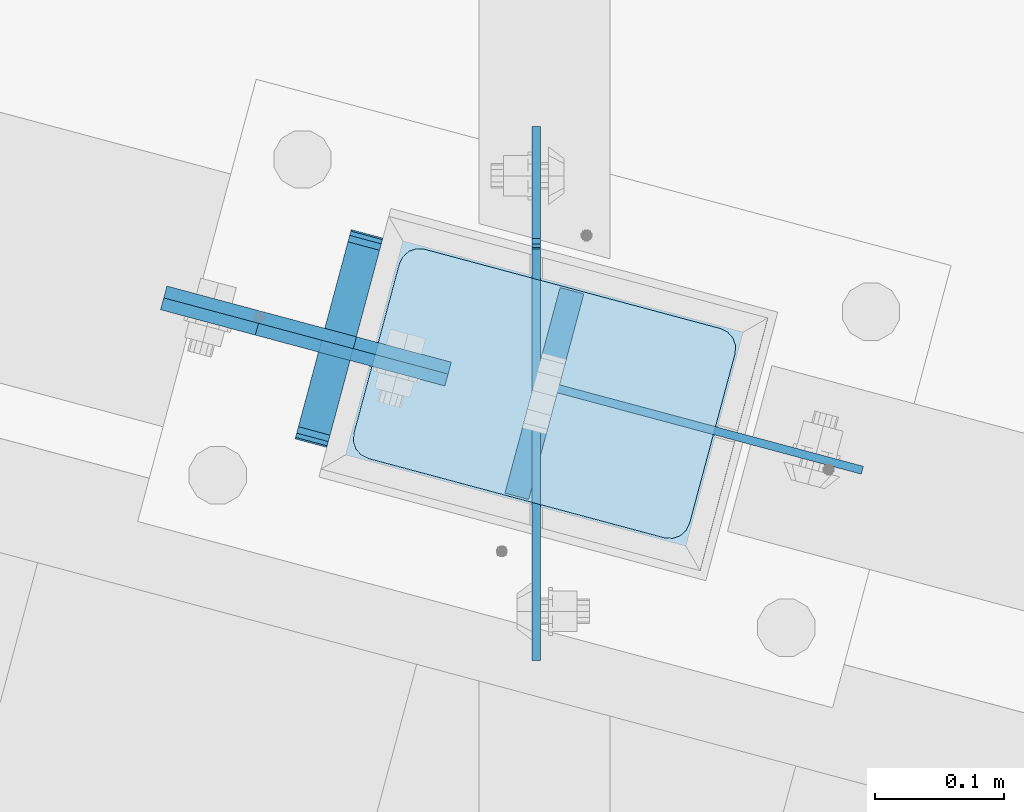
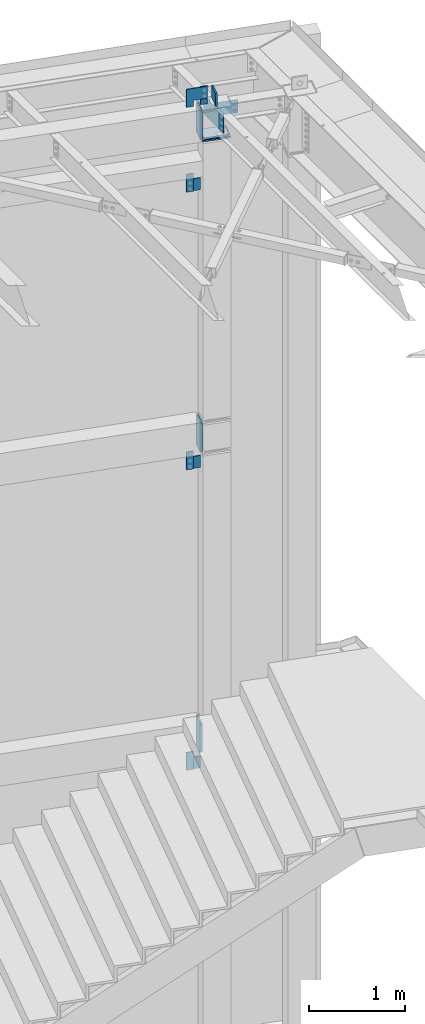
# One storey, part 1702 of 1763: 17 plates, 5 elements without a shape of their own.
"""IFC2X3 building model written with IfcOpenShell, lengths in millimetres."""

from ifc_helpers import new_model, si_unit, frame, origin_with_axes, place, context, subcontext, project, spatial, faceted_brep, material, type_object, element, aggregate, save


model = new_model("IFC2X3")

# Units and contexts
model_context = context("Model", 3, precision=1e-05, world=origin_with_axes())
body_context = subcontext(model_context, "Body", "Model", "MODEL_VIEW")
ifc_project = project(units=[si_unit("LENGTHUNIT", "METRE", prefix="MILLI"), si_unit("AREAUNIT", "SQUARE_METRE"), si_unit("VOLUMEUNIT", "CUBIC_METRE"), si_unit("MASSUNIT", "GRAM", prefix="KILO"), si_unit("TIMEUNIT", "SECOND"), si_unit("PLANEANGLEUNIT", "RADIAN"), si_unit("SOLIDANGLEUNIT", "STERADIAN"), si_unit("THERMODYNAMICTEMPERATUREUNIT", "DEGREE_CELSIUS"), si_unit("LUMINOUSINTENSITYUNIT", "LUMEN")], contexts=[model_context])

# Site, building, storey
site_placement = place(None, origin_with_axes())
site = spatial("IfcSite", under=ifc_project, at=site_placement, CompositionType="ELEMENT")
building_placement = place(site_placement, origin_with_axes())
building = spatial("IfcBuilding", under=site, at=building_placement, Name="Undefined", CompositionType="ELEMENT")
storey_placement = place(building_placement, origin_with_axes())
storey = spatial("IfcBuildingStorey", under=building, at=storey_placement, Name="Undefined", CompositionType="ELEMENT", Elevation=0.0)

# Assembly, plate
assembly_1_placement = place(storey_placement, origin_with_axes())
assembly_1 = element("IfcElementAssembly", 1, at=assembly_1_placement, inside=storey, Name="BEAM", AssemblyPlace="NOTDEFINED", PredefinedType="RIGID_FRAME")
ifc_material_1 = material(Name="STEEL/A36")
plate_type_1 = type_object("IfcPlateType", PredefinedType="NOTDEFINED")
plate_1_placement = place(assembly_1_placement, frame((-22769.6055248915, 62142.4810116845, 11598.2749999997), z_axis=(0.0, 0.0, -1.0), x_axis=(-0.965925827679309, 0.258819039914073, 0.0)))
plate_1 = element("IfcPlate", 2, at=plate_1_placement, type_object=plate_type_1, material=ifc_material_1, Name="PLATE", context=body_context, shape_type="Brep", body=[
    faceted_brep([(0.0, -4.76249999999982, 0.0), (-2.83762346953154e-10, -4.7624999996915, 228.600006103516), (-2.83762346953154e-10, 4.76250000028813, 228.600006103517), (0.0, 4.76249999999982, 0.0), (76.1999969480166, -4.76249999961874, 228.600006103516), (76.1999969480166, 4.76250000036089, 228.600006103517), (76.1999969482931, -4.76249999991705, 0.0), (76.1999969482931, 4.76250000006257, 1.81898940354586e-12)], [[[0, 1, 2, 3]], [[1, 4, 5, 2]], [[4, 6, 7, 5]], [[6, 0, 3, 7]], [[5, 7, 3, 2]], [[6, 4, 1, 0]]]),
])
aggregate(assembly_1, [plate_1])

assembly_2_placement = place(storey_placement, origin_with_axes())
assembly_2 = element("IfcElementAssembly", 3, at=assembly_2_placement, inside=storey, Name="BEAM", AssemblyPlace="NOTDEFINED", PredefinedType="RIGID_FRAME")
plate_2_placement = place(assembly_2_placement, frame((-22769.6007483552, 62142.479719744, 4267.19999999973), z_axis=(0.0, 0.0, -1.0), x_axis=(-0.965925827679309, 0.258819039914073, 0.0)))
plate_2 = element("IfcPlate", 4, at=plate_2_placement, type_object=plate_type_1, material=ifc_material_1, Name="PLATE", context=body_context, shape_type="Brep", body=[
    faceted_brep([(0.0, -4.76249999999982, 0.0), (-2.83762346953154e-10, -4.7624999996915, 228.600006103516), (-2.83762346953154e-10, 4.76250000028813, 228.600006103517), (0.0, 4.76249999999982, 0.0), (76.1999969480166, -4.76249999961874, 228.600006103516), (76.1999969480166, 4.76250000036089, 228.600006103517), (76.1999969482931, -4.76249999991705, 0.0), (76.1999969482931, 4.76250000006257, 1.81898940354586e-12)], [[[0, 1, 2, 3]], [[1, 4, 5, 2]], [[4, 6, 7, 5]], [[6, 0, 3, 7]], [[5, 7, 3, 2]], [[6, 4, 1, 0]]]),
])

assembly_3_placement = place(storey_placement, origin_with_axes())
assembly_3 = element("IfcElementAssembly", 5, at=assembly_3_placement, inside=storey, Name="COLUMN", AssemblyPlace="NOTDEFINED", PredefinedType="RIGID_FRAME")
plate_3_placement = place(assembly_3_placement, frame((-22619.9332028245, 62112.2374404424, 12446.0), z_axis=(0.0, 0.0, 1.0), x_axis=(-0.965925827679309, 0.258819039914073, 0.0)))
plate_3 = element("IfcPlate", 6, at=plate_3_placement, type_object=plate_type_1, material=ifc_material_1, Name="PLATE", context=body_context, shape_type="Brep", body=[
    faceted_brep([(0.0, -4.76249999999982, 0.0), (-2.83762346953154e-10, -4.7624999996915, 228.600006103516), (-2.83762346953154e-10, 4.76250000028813, 228.600006103517), (0.0, 4.76249999999982, 0.0), (76.1999969480166, -4.76249999961874, 228.600006103516), (76.1999969480166, 4.76250000036089, 228.600006103517), (76.1999969482931, -4.76249999991705, 0.0), (76.1999969482931, 4.76250000006257, 1.81898940354586e-12)], [[[0, 1, 2, 3]], [[1, 4, 5, 2]], [[4, 6, 7, 5]], [[6, 0, 3, 7]], [[5, 7, 3, 2]], [[6, 4, 1, 0]]]),
])

assembly_4_placement = place(storey_placement, origin_with_axes())
assembly_4 = element("IfcElementAssembly", 7, at=assembly_4_placement, inside=storey, Name="BEAM", AssemblyPlace="NOTDEFINED", PredefinedType="RIGID_FRAME")
plate_4_placement = place(assembly_4_placement, frame((-22769.6007484359, 62142.4797197657, 8077.19999999973), z_axis=(0.0, 0.0, -1.0), x_axis=(-0.965925827679309, 0.258819039914073, 0.0)))
plate_4 = element("IfcPlate", 8, at=plate_4_placement, type_object=plate_type_1, material=ifc_material_1, Name="PLATE", context=body_context, shape_type="Brep", body=[
    faceted_brep([(0.0, -4.76249999999982, 0.0), (-2.83762346953154e-10, -4.7624999996915, 228.600006103516), (-2.83762346953154e-10, 4.76250000028813, 228.600006103517), (0.0, 4.76249999999982, 0.0), (76.1999969480166, -4.76249999961874, 228.600006103516), (76.1999969480166, 4.76250000036089, 228.600006103517), (76.1999969482931, -4.76249999991705, 0.0), (76.1999969482931, 4.76250000006257, 1.81898940354586e-12)], [[[0, 1, 2, 3]], [[1, 4, 5, 2]], [[4, 6, 7, 5]], [[6, 0, 3, 7]], [[5, 7, 3, 2]], [[6, 4, 1, 0]]]),
])

assembly_5_placement = place(storey_placement, origin_with_axes())
assembly_5 = element("IfcElementAssembly", 9, at=assembly_5_placement, inside=storey, Name="BEAM", AssemblyPlace="NOTDEFINED", PredefinedType="RIGID_FRAME")
plate_type_2 = type_object("IfcPlateType", PredefinedType="NOTDEFINED")
plate_5_placement = place(assembly_5_placement, frame((-22684.0855655107, 62216.539341723, 12057.0970057414), z_axis=(-1.25579324012506e-05, -4.68677477038e-05, 0.999999998822856), x_axis=(-0.258819045024454, -0.965925825091317, -4.85210000061005e-05)))
plate_5 = element("IfcPlate", 10, at=plate_5_placement, type_object=plate_type_2, material=ifc_material_1, Name="PLATE", context=body_context, shape_type="Brep", body=[
    faceted_brep([(-0.000210669619264081, -12.6999999999534, 15.8747893276304), (-0.0047190601399052, -12.6999999998734, 355.599795431186), (-0.00471906022721669, 12.7000000000335, 355.599795431181), (-0.000210669699299615, 12.6999999999462, 15.874789327625), (1.2036328949398, -12.6999999998734, 361.674959615151), (1.20363289484521, 12.7000000000189, 361.674959615146), (4.64488630341657, -12.6999999998734, 366.825251770753), (4.64488630330743, 12.7000000000189, 366.825251770748), (9.79513279069943, -12.6999999998807, 370.266573526937), (9.79513279059029, 12.7000000000116, 370.266573526933), (15.870280938434, -12.6999999998952, 371.47500610361), (15.8702809383467, 12.7000000000044, 371.475006103608), (152.395291187866, -12.7000000001281, 371.475006103574), (152.395291187757, 12.6999999997643, 371.475006103572), (158.470342028959, -12.7000000001353, 370.266613832635), (158.47034202885, 12.699999999757, 370.266613832629), (163.620536872309, -12.7000000001644, 366.825400721296), (163.620536872222, 12.6999999997352, 366.825400721291), (167.061818314192, -12.7000000001644, 361.675251535087), (167.06181831409, 12.6999999997279, 361.675251535082), (168.270291186484, -12.7000000001644, 355.600216727018), (168.270291186389, 12.6999999997279, 355.600216727014), (168.274798528968, -12.7000000002445, 15.8752106238717), (168.274798528873, 12.6999999996478, 15.8752106238662), (167.066446559853, -12.7000000002445, 9.80004645495683), (167.066446559766, 12.6999999996551, 9.80004645495319), (163.625193148131, -12.7000000002372, 4.64975431598214), (163.625193148022, 12.6999999996478, 4.64975431597668), (158.474946666858, -12.7000000002372, 1.2084325724245), (158.474946666771, 12.6999999996624, 1.20843257241904), (152.399798530452, -12.7000000002226, 4.20186552219093e-10), (152.399798530358, 12.6999999996697, 4.14729584008455e-10), (15.8747893290638, -12.6999999999898, 4.72937244921923e-11), (15.8747893289692, 12.6999999999098, 4.36557456851006e-11), (9.79973849928501, -12.699999999968, 1.20839226628777), (9.79973849918315, 12.6999999999243, 1.20839226628414), (4.64954366190068, -12.699999999968, 4.6496053649953), (4.64954366179882, 12.6999999999316, 4.64960536499166), (1.20826221675816, -12.6999999999607, 9.79975453459156), (1.20826221665629, 12.6999999999462, 9.79975453458792)], [[[0, 1, 2, 3]], [[1, 4, 5, 2]], [[4, 6, 7, 5]], [[6, 8, 9, 7]], [[8, 10, 11, 9]], [[10, 12, 13, 11]], [[12, 14, 15, 13]], [[14, 16, 17, 15]], [[16, 18, 19, 17]], [[18, 20, 21, 19]], [[20, 22, 23, 21]], [[22, 24, 25, 23]], [[24, 26, 27, 25]], [[26, 28, 29, 27]], [[28, 30, 31, 29]], [[30, 32, 33, 31]], [[32, 34, 35, 33]], [[34, 36, 37, 35]], [[36, 38, 39, 37]], [[38, 0, 3, 39]], [[5, 7, 9, 11, 13, 15, 17, 19, 21, 23, 25, 27, 29, 31, 33, 35, 37, 39, 3, 2]], [[38, 36, 34, 32, 30, 28, 26, 24, 22, 20, 18, 16, 14, 12, 10, 8, 6, 4, 1, 0]]]),
])

# Plate
plate_6_placement = place(assembly_2_placement, frame((-22684.0593140873, 62216.532307673, 4284.69625868207), z_axis=(-1.25579324012506e-05, -4.68677477038e-05, 0.999999998822856), x_axis=(-0.258819045024454, -0.965925825091317, -4.85210000061005e-05)))
plate_6 = element("IfcPlate", 11, at=plate_6_placement, type_object=plate_type_2, material=ifc_material_1, Name="PLATE", context=body_context, shape_type="Brep", body=[
    faceted_brep([(-0.000210669619264081, -12.6999999999534, 15.8747893276304), (-0.0047190601399052, -12.6999999998734, 355.599795431186), (-0.00471906022721669, 12.7000000000335, 355.599795431181), (-0.000210669699299615, 12.6999999999462, 15.874789327625), (1.2036328949398, -12.6999999998734, 361.674959615151), (1.20363289484521, 12.7000000000189, 361.674959615146), (4.64488630341657, -12.6999999998734, 366.825251770753), (4.64488630330743, 12.7000000000189, 366.825251770748), (9.79513279069943, -12.6999999998807, 370.266573526937), (9.79513279059029, 12.7000000000116, 370.266573526933), (15.870280938434, -12.6999999998952, 371.47500610361), (15.8702809383467, 12.7000000000044, 371.475006103608), (152.395291187866, -12.7000000001281, 371.475006103574), (152.395291187757, 12.6999999997643, 371.475006103572), (158.470342028959, -12.7000000001353, 370.266613832635), (158.47034202885, 12.699999999757, 370.266613832629), (163.620536872309, -12.7000000001644, 366.825400721296), (163.620536872222, 12.6999999997352, 366.825400721291), (167.061818314192, -12.7000000001644, 361.675251535087), (167.06181831409, 12.6999999997279, 361.675251535082), (168.270291186484, -12.7000000001644, 355.600216727018), (168.270291186389, 12.6999999997279, 355.600216727014), (168.274798528968, -12.7000000002445, 15.8752106238717), (168.274798528873, 12.6999999996478, 15.8752106238662), (167.066446559853, -12.7000000002445, 9.80004645495683), (167.066446559766, 12.6999999996551, 9.80004645495319), (163.625193148131, -12.7000000002372, 4.64975431598214), (163.625193148022, 12.6999999996478, 4.64975431597668), (158.474946666858, -12.7000000002372, 1.2084325724245), (158.474946666771, 12.6999999996624, 1.20843257241904), (152.399798530452, -12.7000000002226, 4.20186552219093e-10), (152.399798530358, 12.6999999996697, 4.14729584008455e-10), (15.8747893290638, -12.6999999999898, 4.72937244921923e-11), (15.8747893289692, 12.6999999999098, 4.36557456851006e-11), (9.79973849928501, -12.699999999968, 1.20839226628777), (9.79973849918315, 12.6999999999243, 1.20839226628414), (4.64954366190068, -12.699999999968, 4.6496053649953), (4.64954366179882, 12.6999999999316, 4.64960536499166), (1.20826221675816, -12.6999999999607, 9.79975453459156), (1.20826221665629, 12.6999999999462, 9.79975453458792)], [[[0, 1, 2, 3]], [[1, 4, 5, 2]], [[4, 6, 7, 5]], [[6, 8, 9, 7]], [[8, 10, 11, 9]], [[10, 12, 13, 11]], [[12, 14, 15, 13]], [[14, 16, 17, 15]], [[16, 18, 19, 17]], [[18, 20, 21, 19]], [[20, 22, 23, 21]], [[22, 24, 25, 23]], [[24, 26, 27, 25]], [[26, 28, 29, 27]], [[28, 30, 31, 29]], [[30, 32, 33, 31]], [[32, 34, 35, 33]], [[34, 36, 37, 35]], [[36, 38, 39, 37]], [[38, 0, 3, 39]], [[5, 7, 9, 11, 13, 15, 17, 19, 21, 23, 25, 27, 29, 31, 33, 35, 37, 39, 3, 2]], [[38, 36, 34, 32, 30, 28, 26, 24, 22, 20, 18, 16, 14, 12, 10, 8, 6, 4, 1, 0]]]),
])

aggregate(assembly_2, [plate_6, plate_2])

plate_7_placement = place(assembly_4_placement, frame((-22684.0593141684, 62216.5323076944, 8094.69625868207), z_axis=(-1.25579324012506e-05, -4.68677477038e-05, 0.999999998822856), x_axis=(-0.258819045024454, -0.965925825091317, -4.85210000061005e-05)))
plate_7 = element("IfcPlate", 12, at=plate_7_placement, type_object=plate_type_2, material=ifc_material_1, Name="PLATE", context=body_context, shape_type="Brep", body=[
    faceted_brep([(-0.000210669619264081, -12.6999999999534, 15.8747893276304), (-0.0047190601399052, -12.6999999998734, 355.599795431186), (-0.00471906022721669, 12.7000000000335, 355.599795431181), (-0.000210669699299615, 12.6999999999462, 15.874789327625), (1.2036328949398, -12.6999999998734, 361.674959615151), (1.20363289484521, 12.7000000000189, 361.674959615146), (4.64488630341657, -12.6999999998734, 366.825251770753), (4.64488630330743, 12.7000000000189, 366.825251770748), (9.79513279069943, -12.6999999998807, 370.266573526937), (9.79513279059029, 12.7000000000116, 370.266573526933), (15.870280938434, -12.6999999998952, 371.47500610361), (15.8702809383467, 12.7000000000044, 371.475006103608), (152.395291187866, -12.7000000001281, 371.475006103574), (152.395291187757, 12.6999999997643, 371.475006103572), (158.470342028959, -12.7000000001353, 370.266613832635), (158.47034202885, 12.699999999757, 370.266613832629), (163.620536872309, -12.7000000001644, 366.825400721296), (163.620536872222, 12.6999999997352, 366.825400721291), (167.061818314192, -12.7000000001644, 361.675251535087), (167.06181831409, 12.6999999997279, 361.675251535082), (168.270291186484, -12.7000000001644, 355.600216727018), (168.270291186389, 12.6999999997279, 355.600216727014), (168.274798528968, -12.7000000002445, 15.8752106238717), (168.274798528873, 12.6999999996478, 15.8752106238662), (167.066446559853, -12.7000000002445, 9.80004645495683), (167.066446559766, 12.6999999996551, 9.80004645495319), (163.625193148131, -12.7000000002372, 4.64975431598214), (163.625193148022, 12.6999999996478, 4.64975431597668), (158.474946666858, -12.7000000002372, 1.2084325724245), (158.474946666771, 12.6999999996624, 1.20843257241904), (152.399798530452, -12.7000000002226, 4.20186552219093e-10), (152.399798530358, 12.6999999996697, 4.14729584008455e-10), (15.8747893290638, -12.6999999999898, 4.72937244921923e-11), (15.8747893289692, 12.6999999999098, 4.36557456851006e-11), (9.79973849928501, -12.699999999968, 1.20839226628777), (9.79973849918315, 12.6999999999243, 1.20839226628414), (4.64954366190068, -12.699999999968, 4.6496053649953), (4.64954366179882, 12.6999999999316, 4.64960536499166), (1.20826221675816, -12.6999999999607, 9.79975453459156), (1.20826221665629, 12.6999999999462, 9.79975453458792)], [[[0, 1, 2, 3]], [[1, 4, 5, 2]], [[4, 6, 7, 5]], [[6, 8, 9, 7]], [[8, 10, 11, 9]], [[10, 12, 13, 11]], [[12, 14, 15, 13]], [[14, 16, 17, 15]], [[16, 18, 19, 17]], [[18, 20, 21, 19]], [[20, 22, 23, 21]], [[22, 24, 25, 23]], [[24, 26, 27, 25]], [[26, 28, 29, 27]], [[28, 30, 31, 29]], [[30, 32, 33, 31]], [[32, 34, 35, 33]], [[34, 36, 37, 35]], [[36, 38, 39, 37]], [[38, 0, 3, 39]], [[5, 7, 9, 11, 13, 15, 17, 19, 21, 23, 25, 27, 29, 31, 33, 35, 37, 39, 3, 2]], [[38, 36, 34, 32, 30, 28, 26, 24, 22, 20, 18, 16, 14, 12, 10, 8, 6, 4, 1, 0]]]),
])

aggregate(assembly_4, [plate_7, plate_4])

plate_type_3 = type_object("IfcPlateType", PredefinedType="NOTDEFINED")
plate_8_placement = place(assembly_5_placement, frame((-22843.216222429, 62162.2049370005, 12674.5557703224), z_axis=(9.34215695488093e-05, -2.50278846579022e-05, -0.999999995323008), x_axis=(0.965925824710719, -0.25881903292249, 9.67159999671876e-05)))
plate_8 = element("IfcPlate", 13, at=plate_8_placement, type_object=plate_type_3, material=ifc_material_1, Name="PLATE", context=body_context, shape_type="Brep", body=[
    faceted_brep([(0.0, -4.76249999999982, 0.0), (-0.0147415312894736, -4.76250000055734, 228.577880859459), (-0.0147415312967496, 4.76249999946594, 228.577880859457), (0.0, 4.76249999999982, 0.0), (76.1926269535688, -4.76250000031723, 228.563140869262), (76.1926269535616, 4.76249999970605, 228.563140869261), (76.1999969485987, -4.76250000013533, 152.385253906345), (76.1999969485914, 4.76249999988795, 152.385253906343), (228.59263610909, -4.76249999964057, 152.399993896655), (228.592636109082, 4.76250000037544, 152.399993896655), (228.607376099128, -4.76249999928405, 2.14640749618411e-10), (228.607376099135, 4.76250000073924, 2.12821760214865e-10)], [[[0, 1, 2, 3]], [[1, 4, 5, 2]], [[4, 6, 7, 5]], [[6, 8, 9, 7]], [[8, 10, 11, 9]], [[10, 0, 3, 11]], [[5, 7, 9, 11, 3, 2]], [[10, 8, 6, 4, 1, 0]]]),
])

aggregate(assembly_5, [plate_5, plate_8])

plate_type_4 = type_object("IfcPlateType", PredefinedType="NOTDEFINED")
plate_9_placement = place(assembly_3_placement, frame((-22654.7966634441, 62208.6914009562, 12065.0), z_axis=(0.965913267114843, -0.258865912030785, 0.0), x_axis=(-0.258865912030778, -0.965913267114844, 3.00823476209188e-08)))
plate_9 = element("IfcPlate", 14, at=plate_9_placement, type_object=plate_type_4, material=ifc_material_1, Name="PLATE", context=body_context, shape_type="Brep", body=[
    faceted_brep([(7.27595761418343e-11, -9.52499999999964, 15.8750000001601), (1.13504938781261e-09, -9.52499999999964, 254.000000000065), (1.13504938781261e-09, 9.52499999999964, 254.000000000065), (7.27595761418343e-11, 9.52499999999964, 15.8750000001601), (1.20841242253664, -9.52499999999964, 260.075099488837), (1.20841242253664, 9.52499999999964, 260.075099488837), (4.64967984981922, -9.52499999999964, 265.225320151352), (4.64967984981922, 9.52499999999964, 265.225320151352), (9.79990051234927, -9.52499999999964, 268.666587578613), (9.79990051234927, 9.52499999999964, 268.666587578613), (15.8750000011278, -9.52499999999964, 269.874999999993), (15.8750000011278, 9.52499999999964, 269.874999999993), (152.400009155099, -9.52499999999964, 269.87500000008), (152.400009155099, 9.52499999999964, 269.87500000008), (158.475108643885, -9.52499999999964, 268.6665875787), (158.475108643885, 9.52499999999964, 268.6665875787), (163.625329306429, -9.52499999999964, 265.225320151425), (163.625329306429, 9.52499999999964, 265.225320151425), (167.066596733726, -9.52499999999964, 260.07509948888), (167.066596733726, 9.52499999999964, 260.07509948888), (168.275009155106, -9.52499999999964, 254.000000000087), (168.275009155106, 9.52499999999964, 254.000000000087), (168.275009155259, -9.52499999999964, 15.8750000008658), (168.275009155259, 9.52499999999964, 15.8750000008658), (167.066596733886, -9.52499999999964, 9.79990051209461), (167.066596733886, 9.52499999999964, 9.79990051209461), (163.625329306633, -9.52499999999964, 4.64967984955729), (163.625329306633, 9.52499999999964, 4.64967984955729), (158.475108644117, -9.52499999999964, 1.20841242226743), (158.475108644117, 9.52499999999964, 1.20841242226743), (152.400009155353, -9.52499999999964, 8.58562998473644e-10), (152.400009155353, 9.52499999999964, 8.58562998473644e-10), (15.8750000001673, -9.52499999999964, 8.73114913702011e-11), (15.8750000001673, 9.52499999999964, 8.73114913702011e-11), (9.79990051132336, -9.52499999999964, 1.20841242144525), (9.79990051132336, 9.52499999999964, 1.20841242144525), (4.64967984874238, -9.52499999999964, 4.64967984874238), (4.64967984874238, 9.52499999999964, 4.64967984874238), (1.20841242144525, -9.52499999999964, 9.79990051132336), (1.20841242144525, 9.52499999999964, 9.79990051132336)], [[[0, 1, 2, 3]], [[1, 4, 5, 2]], [[4, 6, 7, 5]], [[6, 8, 9, 7]], [[8, 10, 11, 9]], [[10, 12, 13, 11]], [[12, 14, 15, 13]], [[14, 16, 17, 15]], [[16, 18, 19, 17]], [[18, 20, 21, 19]], [[20, 22, 23, 21]], [[22, 24, 25, 23]], [[24, 26, 27, 25]], [[26, 28, 29, 27]], [[28, 30, 31, 29]], [[30, 32, 33, 31]], [[32, 34, 35, 33]], [[34, 36, 37, 35]], [[36, 38, 39, 37]], [[38, 0, 3, 39]], [[5, 7, 9, 11, 13, 15, 17, 19, 21, 23, 25, 27, 29, 31, 33, 35, 37, 39, 3, 2]], [[38, 36, 34, 32, 30, 28, 26, 24, 22, 20, 18, 16, 14, 12, 10, 8, 6, 4, 1, 0]]]),
])

plate_10_placement = place(assembly_3_placement, frame((-22654.7966635253, 62208.6914009776, 12030.075), z_axis=(0.965913267114843, -0.258865912030785, 0.0), x_axis=(-0.258865912030778, -0.965913267114844, 3.00823476209188e-08)))
plate_10 = element("IfcPlate", 15, at=plate_10_placement, type_object=plate_type_4, material=ifc_material_1, Name="PLATE", context=body_context, shape_type="Brep", body=[
    faceted_brep([(7.27595761418343e-11, -9.52499999999964, 15.8750000001601), (1.13504938781261e-09, -9.52499999999964, 254.000000000065), (1.13504938781261e-09, 9.52499999999964, 254.000000000065), (7.27595761418343e-11, 9.52499999999964, 15.8750000001601), (1.20841242253664, -9.52499999999964, 260.075099488837), (1.20841242253664, 9.52499999999964, 260.075099488837), (4.64967984981922, -9.52499999999964, 265.225320151352), (4.64967984981922, 9.52499999999964, 265.225320151352), (9.79990051234927, -9.52499999999964, 268.666587578613), (9.79990051234927, 9.52499999999964, 268.666587578613), (15.8750000011278, -9.52499999999964, 269.874999999993), (15.8750000011278, 9.52499999999964, 269.874999999993), (152.400009155099, -9.52499999999964, 269.87500000008), (152.400009155099, 9.52499999999964, 269.87500000008), (158.475108643885, -9.52499999999964, 268.6665875787), (158.475108643885, 9.52499999999964, 268.6665875787), (163.625329306429, -9.52499999999964, 265.225320151425), (163.625329306429, 9.52499999999964, 265.225320151425), (167.066596733726, -9.52499999999964, 260.07509948888), (167.066596733726, 9.52499999999964, 260.07509948888), (168.275009155106, -9.52499999999964, 254.000000000087), (168.275009155106, 9.52499999999964, 254.000000000087), (168.275009155259, -9.52499999999964, 15.8750000008658), (168.275009155259, 9.52499999999964, 15.8750000008658), (167.066596733886, -9.52499999999964, 9.79990051209461), (167.066596733886, 9.52499999999964, 9.79990051209461), (163.625329306633, -9.52499999999964, 4.64967984955729), (163.625329306633, 9.52499999999964, 4.64967984955729), (158.475108644117, -9.52499999999964, 1.20841242226743), (158.475108644117, 9.52499999999964, 1.20841242226743), (152.400009155353, -9.52499999999964, 8.58562998473644e-10), (152.400009155353, 9.52499999999964, 8.58562998473644e-10), (15.8750000001673, -9.52499999999964, 8.73114913702011e-11), (15.8750000001673, 9.52499999999964, 8.73114913702011e-11), (9.79990051132336, -9.52499999999964, 1.20841242144525), (9.79990051132336, 9.52499999999964, 1.20841242144525), (4.64967984874238, -9.52499999999964, 4.64967984874238), (4.64967984874238, 9.52499999999964, 4.64967984874238), (1.20841242144525, -9.52499999999964, 9.79990051132336), (1.20841242144525, 9.52499999999964, 9.79990051132336)], [[[0, 1, 2, 3]], [[1, 4, 5, 2]], [[4, 6, 7, 5]], [[6, 8, 9, 7]], [[8, 10, 11, 9]], [[10, 12, 13, 11]], [[12, 14, 15, 13]], [[14, 16, 17, 15]], [[16, 18, 19, 17]], [[18, 20, 21, 19]], [[20, 22, 23, 21]], [[22, 24, 25, 23]], [[24, 26, 27, 25]], [[26, 28, 29, 27]], [[28, 30, 31, 29]], [[30, 32, 33, 31]], [[32, 34, 35, 33]], [[34, 36, 37, 35]], [[36, 38, 39, 37]], [[38, 0, 3, 39]], [[5, 7, 9, 11, 13, 15, 17, 19, 21, 23, 25, 27, 29, 31, 33, 35, 37, 39, 3, 2]], [[38, 36, 34, 32, 30, 28, 26, 24, 22, 20, 18, 16, 14, 12, 10, 8, 6, 4, 1, 0]]]),
])

ifc_material_2 = material(Name="STEEL/A572-50")
plate_type_5 = type_object("IfcPlateType", PredefinedType="NOTDEFINED")
plate_11_placement = place(assembly_3_placement, frame((-22667.1434837782, 62230.079108951, 12047.5375), z_axis=(0.965913267114843, -0.258865912030785, 0.0), x_axis=(-0.258865912030778, -0.965913267114844, 3.00823476209188e-08)))
plate_11 = element("IfcPlate", 16, at=plate_11_placement, type_object=plate_type_5, material=ifc_material_2, Name="PLATE", context=body_context, shape_type="Brep", body=[
    faceted_brep([(-7.27595761418343e-12, -7.9375, 0.0), (-1.96450855582952e-10, -7.9375, 304.799987792954), (-1.96450855582952e-10, 7.9375, 304.799987792954), (-7.27595761418343e-12, 7.9375, 0.0), (203.199996948031, -7.9375, 304.799987793078), (203.199996948031, 7.9375, 304.799987793078), (203.199996948228, -7.9375, 1.30967237055302e-10), (203.199996948228, 7.9375, 1.30967237055302e-10)], [[[0, 1, 2, 3]], [[1, 4, 5, 2]], [[4, 6, 7, 5]], [[6, 0, 3, 7]], [[5, 7, 3, 2]], [[6, 4, 1, 0]]]),
])

plate_type_6 = type_object("IfcPlateType", PredefinedType="NOTDEFINED")
plate_12_placement = place(assembly_3_placement, frame((-22552.6796172713, 61981.8308951613, 12433.3), z_axis=(0.0, 0.0, -1.0), x_axis=(0.0, 1.0, 0.0)))
plate_12 = element("IfcPlate", 17, at=plate_12_placement, type_object=plate_type_6, material=ifc_material_1, Name="PLATE", context=body_context, shape_type="Brep", body=[
    faceted_brep([(26.0334663149697, -3.17499999999927, 0.0), (24.331334401475, 3.17499999999927, 0.0), (24.3313344014678, 3.17499999999927, 25.3999996185321), (26.0334663149624, -3.17499999999927, 25.3999996185321), (200.249065164971, -3.17499999999927, 25.3999996185321), (198.546933251469, 3.17499999999927, 25.3999996185321), (198.546933251469, 3.17499999999927, 0.0), (200.249065164971, -3.17499999999927, 0.0), (1.81898940354586e-12, -3.17500000000291, 0.0), (-96.5490798950195, -3.17499999999927, 0.0), (-96.5490798950195, 3.17499999999927, 0.0), (-1.81898940354586e-12, 3.17499999997381, 0.0), (-96.5490798950195, -3.17499999999927, 254.0), (-96.5490798950195, 3.17499999999927, 254.0), (317.918121337891, -3.17499999999927, 254.0), (317.918121337891, 3.17499999999927, 254.0), (317.918121337891, -3.17499999999927, 25.3999996185303), (317.918121337891, 3.17499999999927, 25.3999996185303), (235.770861625671, -3.17499999999927, 25.3999996185303), (235.770861625671, 3.17499999999927, 25.3999996185303), (230.910782107625, -3.17499999999927, 24.4332696959427), (230.910782107625, 3.17499999999927, 24.4332696959427), (226.790605639471, -3.17499999999927, 21.6802557954652), (226.790605639471, 3.17499999999927, 21.6802557954652), (224.037591738997, -3.17499999999927, 17.5600793273115), (224.037591738997, 3.17499999999927, 17.5600793273115), (223.070861816406, -3.17499999999927, 12.6999998092651), (223.070861816406, 3.17499999999927, 12.6999998092651), (223.070861816406, -3.17499999999927, 0.0), (223.070861816406, 3.17499999999927, 0.0)], [[[0, 1, 2, 3]], [[4, 5, 6, 7]], [[3, 2, 5, 4]], [[8, 9, 10, 11]], [[9, 12, 13, 10]], [[12, 14, 15, 13]], [[14, 16, 17, 15]], [[16, 18, 19, 17]], [[18, 20, 21, 19]], [[20, 22, 23, 21]], [[22, 24, 25, 23]], [[24, 26, 27, 25]], [[26, 28, 29, 27]], [[29, 28, 7, 6]], [[1, 11, 10, 13, 15, 17, 19, 21, 23, 25, 27, 29, 6, 5, 2]], [[8, 11, 1, 0]], [[28, 26, 24, 22, 20, 18, 16, 14, 12, 9, 8, 0, 3, 4, 7]]]),
])

plate_type_7 = type_object("IfcPlateType", PredefinedType="NOTDEFINED")
plate_13_placement = place(assembly_3_placement, frame((-22385.2116135348, 62055.9179836625, 12433.3), z_axis=(0.0, 0.0, -1.0), x_axis=(-0.965925827679309, 0.258819039914073, 0.0)))
plate_13 = element("IfcPlate", 18, at=plate_13_placement, type_object=plate_type_7, material=ifc_material_1, Name="PLATE", context=body_context, shape_type="Brep", body=[
    faceted_brep([(1.81898940354586e-12, -3.17500000000291, 0.0), (-88.9030838011531, -3.17499999983556, 0.0), (-88.9030838011531, 3.17500000018481, 0.0), (-1.81898940354586e-12, 3.17499999997381, 0.0), (-88.9030838011531, -3.17499999983556, 165.100006103516), (-88.9030838011531, 3.17500000018481, 165.100006103516), (169.86250305154, -3.17500000032305, 165.100006103516), (169.862503051532, 3.17499999969732, 165.100006103516), (169.86250305154, -3.17500000032305, 0.0), (169.862503051532, 3.17499999969732, 0.0)], [[[0, 1, 2, 3]], [[1, 4, 5, 2]], [[4, 6, 7, 5]], [[6, 8, 9, 7]], [[8, 0, 3, 9]], [[5, 7, 9, 3, 2]], [[8, 6, 4, 1, 0]]]),
])

plate_type_8 = type_object("IfcPlateType", PredefinedType="NOTDEFINED")
plate_14_placement = place(assembly_3_placement, frame((-22840.7390422212, 62171.4021729101, 4038.59999389621), z_axis=(0.0, 0.0, 1.0), x_axis=(0.965925826295336, -0.25881904507913, 0.0)))
plate_14 = element("IfcPlate", 19, at=plate_14_placement, type_object=plate_type_8, material=ifc_material_1, Name="PLATE", context=body_context, shape_type="Brep", body=[
    faceted_brep([(0.0, -4.76249999999982, 0.0), (-3.05175672110636e-06, -4.7625000002663, 152.399993896484), (-3.05175490211695e-06, 4.76249999972788, 152.399993896484), (0.0, 4.76249999999982, 0.0), (152.400009155272, -4.76249999975698, 152.399993896484), (152.400009155273, 4.76250000024447, 152.399993896484), (152.400009155272, -4.76249999948777, 5.45696821063757e-12), (152.400009155273, 4.76250000051368, 3.63797880709171e-12)], [[[0, 1, 2, 3]], [[1, 4, 5, 2]], [[4, 6, 7, 5]], [[6, 0, 3, 7]], [[5, 7, 3, 2]], [[6, 4, 1, 0]]]),
])

plate_15_placement = place(assembly_3_placement, frame((-22840.7390422212, 62171.4021729101, 7848.59999389621), z_axis=(0.0, 0.0, 1.0), x_axis=(0.965925826295336, -0.25881904507913, 0.0)))
plate_15 = element("IfcPlate", 20, at=plate_15_placement, type_object=plate_type_8, material=ifc_material_1, Name="PLATE", context=body_context, shape_type="Brep", body=[
    faceted_brep([(0.0, -4.76249999999982, 0.0), (-3.05175672110636e-06, -4.7625000002663, 152.399993896484), (-3.05175490211695e-06, 4.76249999972788, 152.399993896484), (0.0, 4.76249999999982, 0.0), (152.400009155272, -4.76249999975698, 152.399993896484), (152.400009155273, 4.76250000024447, 152.399993896484), (152.400009155272, -4.76249999948777, 5.45696821063757e-12), (152.400009155273, 4.76250000051368, 3.63797880709171e-12)], [[[0, 1, 2, 3]], [[1, 4, 5, 2]], [[4, 6, 7, 5]], [[6, 0, 3, 7]], [[5, 7, 3, 2]], [[6, 4, 1, 0]]]),
])

plate_16_placement = place(assembly_3_placement, frame((-22840.739053975, 62171.40217606, 11369.6749938962), z_axis=(0.0, 0.0, 1.0), x_axis=(0.965925826295336, -0.25881904507913, 0.0)))
plate_16 = element("IfcPlate", 21, at=plate_16_placement, type_object=plate_type_8, material=ifc_material_1, Name="PLATE", context=body_context, shape_type="Brep", body=[
    faceted_brep([(0.0, -4.76249999999982, 0.0), (-3.05175672110636e-06, -4.7625000002663, 152.399993896484), (-3.05175490211695e-06, 4.76249999972788, 152.399993896484), (0.0, 4.76249999999982, 0.0), (152.400009155272, -4.76249999975698, 152.399993896484), (152.400009155273, 4.76250000024447, 152.399993896484), (152.400009155272, -4.76249999948777, 5.45696821063757e-12), (152.400009155273, 4.76250000051368, 3.63797880709171e-12)], [[[0, 1, 2, 3]], [[1, 4, 5, 2]], [[4, 6, 7, 5]], [[6, 0, 3, 7]], [[5, 7, 3, 2]], [[6, 4, 1, 0]]]),
])

plate_type_9 = type_object("IfcPlateType", PredefinedType="NOTDEFINED")
plate_17_placement = place(assembly_3_placement, frame((-22524.9357933869, 62172.3427640588, 12611.0999908447), z_axis=(0.0, 0.0, -1.0), x_axis=(-0.258911937048181, -0.965900931179776, 0.0)))
plate_17 = element("IfcPlate", 22, at=plate_17_placement, type_object=plate_type_9, material=ifc_material_2, Name="PLATE", context=body_context, shape_type="Brep", body=[
    faceted_brep([(7.27595761418343e-12, 9.52500000000146, 155.574990844727), (-1.45519152283669e-11, 7.27595761418343e-12, 165.099990844727), (165.288833618244, 2.18278728425503e-10, 165.099990844727), (165.288833618273, 9.52500000021973, 155.574990844727), (-3.63797880709171e-11, -9.5249999999869, 155.574990844727), (165.288833618222, -9.5249999997759, 155.574990844727), (0.0, 9.52500000000146, 0.0), (0.0, -9.52500000000146, 0.0), (165.288833618222, -9.5249999997759, 0.0), (165.288833618273, 9.52500000021973, 0.0)], [[[0, 1, 2, 3]], [[1, 4, 5, 2]], [[6, 7, 4, 1, 0]], [[5, 8, 9, 3, 2]], [[8, 7, 6, 9]], [[9, 6, 0, 3]], [[7, 8, 5, 4]]]),
])

aggregate(assembly_3, [plate_9, plate_10, plate_11, plate_12, plate_13, plate_17, plate_3, plate_14, plate_15, plate_16])

save(model, "model.ifc")
